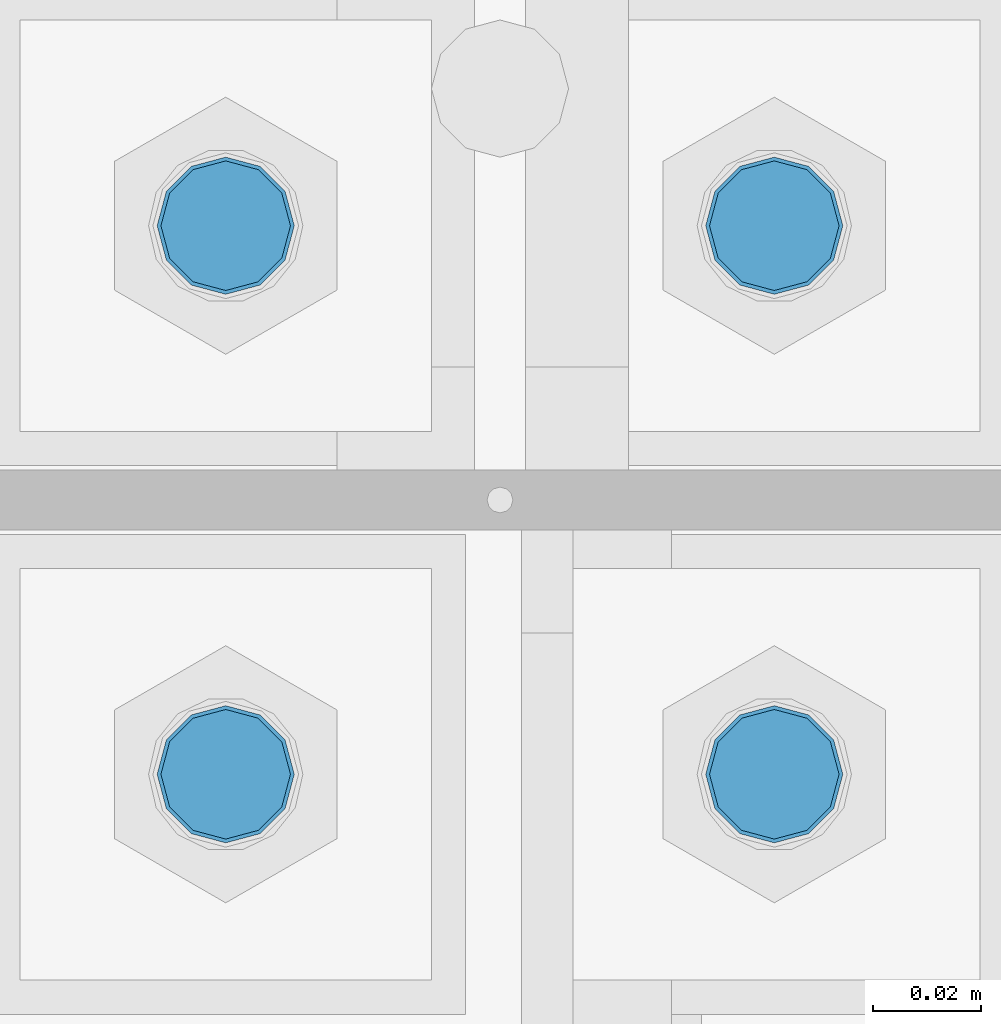
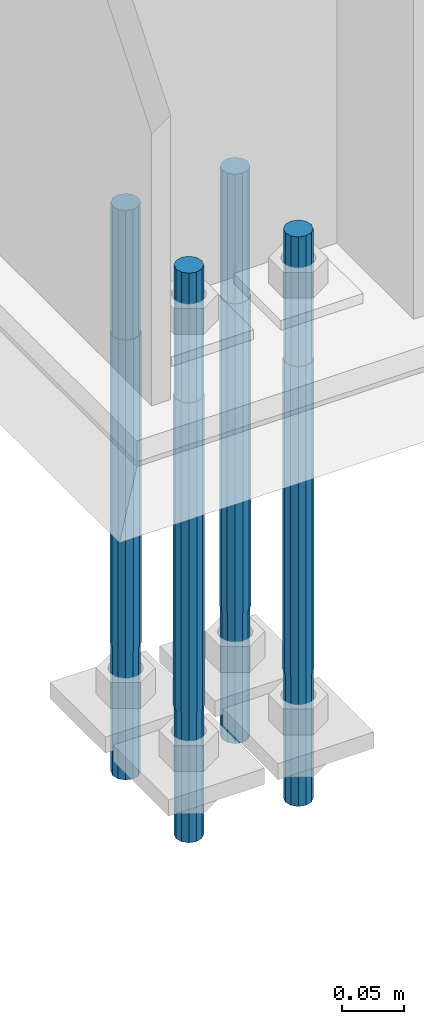
# One storey, part 1573 of 3843: 4 columns, 1 element without a shape of its own.
"""IFC2X3 building model written with IfcOpenShell, lengths in millimetres."""

from ifc_helpers import new_model, si_unit, frame, origin_with_axes, place, context, subcontext, project, spatial, faceted_brep, material, type_object, element, aggregate, save


model = new_model("IFC2X3")

# Units and contexts
model_context = context("Model", 3, precision=1e-05, world=origin_with_axes())
body_context = subcontext(model_context, "Body", "Model", "MODEL_VIEW")
ifc_project = project(units=[si_unit("LENGTHUNIT", "METRE", prefix="MILLI"), si_unit("AREAUNIT", "SQUARE_METRE"), si_unit("VOLUMEUNIT", "CUBIC_METRE"), si_unit("MASSUNIT", "GRAM", prefix="KILO"), si_unit("TIMEUNIT", "SECOND"), si_unit("PLANEANGLEUNIT", "RADIAN"), si_unit("SOLIDANGLEUNIT", "STERADIAN"), si_unit("THERMODYNAMICTEMPERATUREUNIT", "DEGREE_CELSIUS"), si_unit("LUMINOUSINTENSITYUNIT", "LUMEN")], contexts=[model_context])

# Site, building, storey
site_placement = place(None, origin_with_axes())
site = spatial("IfcSite", under=ifc_project, at=site_placement, CompositionType="ELEMENT")
building_placement = place(site_placement, origin_with_axes())
building = spatial("IfcBuilding", under=site, at=building_placement, Name="Undefined", CompositionType="ELEMENT")
storey_placement = place(building_placement, origin_with_axes())
storey = spatial("IfcBuildingStorey", under=building, at=storey_placement, Name="Undefined", CompositionType="ELEMENT", Elevation=0.0)

# Assembly, columns
assembly_placement = place(storey_placement, origin_with_axes())
assembly = element("IfcElementAssembly", 1, at=assembly_placement, inside=storey, Name="TEMPLATE", AssemblyPlace="NOTDEFINED", PredefinedType="RIGID_FRAME")
ifc_material = material(Name="Undefined/F1554-GR.55")
column_type = type_object("IfcColumnType", PredefinedType="NOTDEFINED")
column_1_placement = place(assembly_placement, frame((36626.8, 89065.1, 30022.8), z_axis=(1.0, 0.0, 0.0), x_axis=(0.0, 0.0, -1.0)))
column_1 = element("IfcColumn", 2, at=column_1_placement, type_object=column_type, material=ifc_material, Name="ANCHOR_ROD", context=body_context, shape_type="Brep", body=[
    faceted_brep([(-127.0, -10.3923048454162, 6.0), (-127.0, -6.0, 10.3923048454126), (-127.0, 0.0, 12.0), (-127.0, 6.0, 10.3923048454126), (-127.0, 10.3923048454162, 6.0), (-127.0, 12.0, 0.0), (-127.0, 10.3923048454162, -6.0), (-127.0, 6.0, -10.3923048454126), (-127.0, 0.0, -12.0), (-127.0, -6.0, -10.3923048454126), (-127.0, -10.3923048454162, -6.0), (-127.0, -12.0, 0.0), (0.0, 12.0, 0.0), (0.0, 10.3923048454162, -6.0), (0.0, 6.0, -10.3923048454126), (0.0, 0.0, -12.0), (0.0, -6.0, -10.3923048454126), (0.0, -10.3923048454162, -6.0), (0.0, -12.0, 0.0), (0.0, -10.3923048454162, 6.0), (0.0, -6.0, 10.3923048454126), (0.0, 0.0, 12.0), (0.0, 6.0, 10.3923048454126), (0.0, 10.3923048454162, 6.0), (0.0, -10.9985226280696, 6.34999999999854), (0.0, -6.35000000000582, 10.9985226280623), (0.0, 0.0, 12.6999999999971), (0.0, 6.35000000000582, 10.9985226280623), (0.0, 10.9985226280696, 6.34999999999854), (0.0, 12.6999999999971, 0.0), (0.0, 10.9985226280696, -6.34999999999854), (0.0, 6.35000000000582, -10.9985226280623), (0.0, 0.0, -12.6999999999971), (0.0, -6.35000000000582, -10.9985226280623), (0.0, -10.9985226280696, -6.34999999999854), (0.0, -12.6999999999971, 0.0), (304.799999999999, -12.6999999999971, 0.0), (304.799999999999, -10.9985226280623, 6.35000000000036), (304.799999999999, -6.34999999999854, 10.9985226280623), (304.799999999999, 0.0, 12.7000000000007), (304.799999999999, 6.34999999999854, 10.9985226280623), (304.799999999999, 10.9985226280623, 6.35000000000036), (304.799999999999, 12.6999999999971, 0.0), (304.799999999999, 10.9985226280623, -6.35000000000036), (304.799999999999, 6.34999999999854, -10.9985226280623), (304.799999999999, 0.0, -12.7000000000007), (304.799999999999, -6.34999999999854, -10.9985226280623), (304.799999999999, -10.9985226280623, -6.35000000000036), (304.799999999999, -6.0, 10.3923048454126), (304.799999999999, 0.0, 12.0), (304.799999999999, 6.0, 10.3923048454126), (304.799999999999, 10.3923048454162, 6.0), (304.799999999999, 12.0, 0.0), (304.799999999999, 10.3923048454162, -6.0), (304.799999999999, 6.0, -10.3923048454126), (304.799999999999, 0.0, -12.0), (304.799999999999, -6.0, -10.3923048454126), (304.799999999999, -10.3923048454162, -6.0), (304.799999999999, -12.0, 0.0), (304.799999999999, -10.3923048454162, 6.0), (431.799999999999, -6.0, -10.3923048454126), (431.799999999999, 0.0, -12.0), (431.799999999999, 6.0, -10.3923048454126), (431.799999999999, 10.3923048454162, -6.0), (431.799999999999, 12.0, 0.0), (431.799999999999, 10.3923048454162, 6.0), (431.799999999999, 6.0, 10.3923048454126), (431.799999999999, 0.0, 12.0), (431.799999999999, -6.0, 10.3923048454126), (431.799999999999, -10.3923048454162, 6.0), (431.799999999999, -12.0, 0.0), (431.799999999999, -10.3923048454162, -6.0)], [[[0, 1, 2, 3, 4, 5, 6, 7, 8, 9, 10, 11]], [[6, 5, 12, 13]], [[7, 6, 13, 14]], [[8, 7, 14, 15]], [[9, 8, 15, 16]], [[10, 9, 16, 17]], [[11, 10, 17, 18]], [[0, 11, 18, 19]], [[1, 0, 19, 20]], [[2, 1, 20, 21]], [[3, 2, 21, 22]], [[4, 3, 22, 23]], [[5, 4, 23, 12]], [[24, 25, 26, 27, 28, 29, 30, 31, 32, 33, 34, 35], [22, 21, 20, 19, 18, 17, 16, 15, 14, 13, 12, 23]], [[24, 35, 36, 37]], [[25, 24, 37, 38]], [[26, 25, 38, 39]], [[27, 26, 39, 40]], [[28, 27, 40, 41]], [[29, 28, 41, 42]], [[30, 29, 42, 43]], [[31, 30, 43, 44]], [[32, 31, 44, 45]], [[33, 32, 45, 46]], [[34, 33, 46, 47]], [[35, 34, 47, 36]], [[46, 45, 44, 43, 42, 41, 40, 39, 38, 37, 36, 47], [48, 49, 50, 51, 52, 53, 54, 55, 56, 57, 58, 59]], [[60, 61, 62, 63, 64, 65, 66, 67, 68, 69, 70, 71]], [[68, 67, 49, 48]], [[69, 68, 48, 59]], [[70, 69, 59, 58]], [[71, 70, 58, 57]], [[60, 71, 57, 56]], [[61, 60, 56, 55]], [[62, 61, 55, 54]], [[63, 62, 54, 53]], [[64, 63, 53, 52]], [[65, 64, 52, 51]], [[66, 65, 51, 50]], [[67, 66, 50, 49]]]),
])
column_2_placement = place(assembly_placement, frame((36626.8, 89166.7, 30022.8), z_axis=(-1.0, 0.0, 0.0), x_axis=(0.0, 0.0, -1.0)))
column_2 = element("IfcColumn", 3, at=column_2_placement, type_object=column_type, material=ifc_material, Name="ANCHOR_ROD", context=body_context, shape_type="Brep", body=[
    faceted_brep([(-127.0, -10.3923048454162, 6.0), (-127.0, -6.0, 10.3923048454126), (-127.0, 0.0, 12.0), (-127.0, 6.0, 10.3923048454126), (-127.0, 10.3923048454162, 6.0), (-127.0, 12.0, 0.0), (-127.0, 10.3923048454162, -6.0), (-127.0, 6.0, -10.3923048454126), (-127.0, 0.0, -12.0), (-127.0, -6.0, -10.3923048454126), (-127.0, -10.3923048454162, -6.0), (-127.0, -12.0, 0.0), (0.0, 12.0, 0.0), (0.0, 10.3923048454162, -6.0), (0.0, 6.0, -10.3923048454126), (0.0, 0.0, -12.0), (0.0, -6.0, -10.3923048454126), (0.0, -10.3923048454162, -6.0), (0.0, -12.0, 0.0), (0.0, -10.3923048454162, 6.0), (0.0, -6.0, 10.3923048454126), (0.0, 0.0, 12.0), (0.0, 6.0, 10.3923048454126), (0.0, 10.3923048454162, 6.0), (0.0, -10.9985226280696, 6.34999999999854), (0.0, -6.35000000000582, 10.9985226280623), (0.0, 0.0, 12.6999999999971), (0.0, 6.35000000000582, 10.9985226280623), (0.0, 10.9985226280696, 6.34999999999854), (0.0, 12.6999999999971, 0.0), (0.0, 10.9985226280696, -6.34999999999854), (0.0, 6.35000000000582, -10.9985226280623), (0.0, 0.0, -12.6999999999971), (0.0, -6.35000000000582, -10.9985226280623), (0.0, -10.9985226280696, -6.34999999999854), (0.0, -12.6999999999971, 0.0), (304.799999999999, -12.6999999999971, 0.0), (304.799999999999, -10.9985226280623, 6.35000000000036), (304.799999999999, -6.34999999999854, 10.9985226280623), (304.799999999999, 0.0, 12.7000000000007), (304.799999999999, 6.34999999999854, 10.9985226280623), (304.799999999999, 10.9985226280623, 6.35000000000036), (304.799999999999, 12.6999999999971, 0.0), (304.799999999999, 10.9985226280623, -6.35000000000036), (304.799999999999, 6.34999999999854, -10.9985226280623), (304.799999999999, 0.0, -12.7000000000007), (304.799999999999, -6.34999999999854, -10.9985226280623), (304.799999999999, -10.9985226280623, -6.35000000000036), (304.799999999999, -6.0, 10.3923048454126), (304.799999999999, 0.0, 12.0), (304.799999999999, 6.0, 10.3923048454126), (304.799999999999, 10.3923048454162, 6.0), (304.799999999999, 12.0, 0.0), (304.799999999999, 10.3923048454162, -6.0), (304.799999999999, 6.0, -10.3923048454126), (304.799999999999, 0.0, -12.0), (304.799999999999, -6.0, -10.3923048454126), (304.799999999999, -10.3923048454162, -6.0), (304.799999999999, -12.0, 0.0), (304.799999999999, -10.3923048454162, 6.0), (431.799999999999, -6.0, -10.3923048454126), (431.799999999999, 0.0, -12.0), (431.799999999999, 6.0, -10.3923048454126), (431.799999999999, 10.3923048454162, -6.0), (431.799999999999, 12.0, 0.0), (431.799999999999, 10.3923048454162, 6.0), (431.799999999999, 6.0, 10.3923048454126), (431.799999999999, 0.0, 12.0), (431.799999999999, -6.0, 10.3923048454126), (431.799999999999, -10.3923048454162, 6.0), (431.799999999999, -12.0, 0.0), (431.799999999999, -10.3923048454162, -6.0)], [[[0, 1, 2, 3, 4, 5, 6, 7, 8, 9, 10, 11]], [[6, 5, 12, 13]], [[7, 6, 13, 14]], [[8, 7, 14, 15]], [[9, 8, 15, 16]], [[10, 9, 16, 17]], [[11, 10, 17, 18]], [[0, 11, 18, 19]], [[1, 0, 19, 20]], [[2, 1, 20, 21]], [[3, 2, 21, 22]], [[4, 3, 22, 23]], [[5, 4, 23, 12]], [[24, 25, 26, 27, 28, 29, 30, 31, 32, 33, 34, 35], [22, 21, 20, 19, 18, 17, 16, 15, 14, 13, 12, 23]], [[24, 35, 36, 37]], [[25, 24, 37, 38]], [[26, 25, 38, 39]], [[27, 26, 39, 40]], [[28, 27, 40, 41]], [[29, 28, 41, 42]], [[30, 29, 42, 43]], [[31, 30, 43, 44]], [[32, 31, 44, 45]], [[33, 32, 45, 46]], [[34, 33, 46, 47]], [[35, 34, 47, 36]], [[46, 45, 44, 43, 42, 41, 40, 39, 38, 37, 36, 47], [48, 49, 50, 51, 52, 53, 54, 55, 56, 57, 58, 59]], [[60, 61, 62, 63, 64, 65, 66, 67, 68, 69, 70, 71]], [[68, 67, 49, 48]], [[69, 68, 48, 59]], [[70, 69, 59, 58]], [[71, 70, 58, 57]], [[60, 71, 57, 56]], [[61, 60, 56, 55]], [[62, 61, 55, 54]], [[63, 62, 54, 53]], [[64, 63, 53, 52]], [[65, 64, 52, 51]], [[66, 65, 51, 50]], [[67, 66, 50, 49]]]),
])
column_3_placement = place(assembly_placement, frame((36525.2, 89065.1, 30022.8), z_axis=(1.0, 0.0, 0.0), x_axis=(0.0, 0.0, -1.0)))
column_3 = element("IfcColumn", 4, at=column_3_placement, type_object=column_type, material=ifc_material, Name="ANCHOR_ROD", context=body_context, shape_type="Brep", body=[
    faceted_brep([(-127.0, -10.3923048454162, 6.0), (-127.0, -6.0, 10.3923048454126), (-127.0, 0.0, 12.0), (-127.0, 6.0, 10.3923048454126), (-127.0, 10.3923048454162, 6.0), (-127.0, 12.0, 0.0), (-127.0, 10.3923048454162, -6.0), (-127.0, 6.0, -10.3923048454126), (-127.0, 0.0, -12.0), (-127.0, -6.0, -10.3923048454126), (-127.0, -10.3923048454162, -6.0), (-127.0, -12.0, 0.0), (0.0, 12.0, 0.0), (0.0, 10.3923048454162, -6.0), (0.0, 6.0, -10.3923048454126), (0.0, 0.0, -12.0), (0.0, -6.0, -10.3923048454126), (0.0, -10.3923048454162, -6.0), (0.0, -12.0, 0.0), (0.0, -10.3923048454162, 6.0), (0.0, -6.0, 10.3923048454126), (0.0, 0.0, 12.0), (0.0, 6.0, 10.3923048454126), (0.0, 10.3923048454162, 6.0), (0.0, -10.9985226280696, 6.34999999999854), (0.0, -6.35000000000582, 10.9985226280623), (0.0, 0.0, 12.6999999999971), (0.0, 6.35000000000582, 10.9985226280623), (0.0, 10.9985226280696, 6.34999999999854), (0.0, 12.6999999999971, 0.0), (0.0, 10.9985226280696, -6.34999999999854), (0.0, 6.35000000000582, -10.9985226280623), (0.0, 0.0, -12.6999999999971), (0.0, -6.35000000000582, -10.9985226280623), (0.0, -10.9985226280696, -6.34999999999854), (0.0, -12.6999999999971, 0.0), (304.799999999999, -12.6999999999971, 0.0), (304.799999999999, -10.9985226280623, 6.35000000000036), (304.799999999999, -6.34999999999854, 10.9985226280623), (304.799999999999, 0.0, 12.7000000000007), (304.799999999999, 6.34999999999854, 10.9985226280623), (304.799999999999, 10.9985226280623, 6.35000000000036), (304.799999999999, 12.6999999999971, 0.0), (304.799999999999, 10.9985226280623, -6.35000000000036), (304.799999999999, 6.34999999999854, -10.9985226280623), (304.799999999999, 0.0, -12.7000000000007), (304.799999999999, -6.34999999999854, -10.9985226280623), (304.799999999999, -10.9985226280623, -6.35000000000036), (304.799999999999, -6.0, 10.3923048454126), (304.799999999999, 0.0, 12.0), (304.799999999999, 6.0, 10.3923048454126), (304.799999999999, 10.3923048454162, 6.0), (304.799999999999, 12.0, 0.0), (304.799999999999, 10.3923048454162, -6.0), (304.799999999999, 6.0, -10.3923048454126), (304.799999999999, 0.0, -12.0), (304.799999999999, -6.0, -10.3923048454126), (304.799999999999, -10.3923048454162, -6.0), (304.799999999999, -12.0, 0.0), (304.799999999999, -10.3923048454162, 6.0), (431.799999999999, -6.0, -10.3923048454126), (431.799999999999, 0.0, -12.0), (431.799999999999, 6.0, -10.3923048454126), (431.799999999999, 10.3923048454162, -6.0), (431.799999999999, 12.0, 0.0), (431.799999999999, 10.3923048454162, 6.0), (431.799999999999, 6.0, 10.3923048454126), (431.799999999999, 0.0, 12.0), (431.799999999999, -6.0, 10.3923048454126), (431.799999999999, -10.3923048454162, 6.0), (431.799999999999, -12.0, 0.0), (431.799999999999, -10.3923048454162, -6.0)], [[[0, 1, 2, 3, 4, 5, 6, 7, 8, 9, 10, 11]], [[6, 5, 12, 13]], [[7, 6, 13, 14]], [[8, 7, 14, 15]], [[9, 8, 15, 16]], [[10, 9, 16, 17]], [[11, 10, 17, 18]], [[0, 11, 18, 19]], [[1, 0, 19, 20]], [[2, 1, 20, 21]], [[3, 2, 21, 22]], [[4, 3, 22, 23]], [[5, 4, 23, 12]], [[24, 25, 26, 27, 28, 29, 30, 31, 32, 33, 34, 35], [22, 21, 20, 19, 18, 17, 16, 15, 14, 13, 12, 23]], [[24, 35, 36, 37]], [[25, 24, 37, 38]], [[26, 25, 38, 39]], [[27, 26, 39, 40]], [[28, 27, 40, 41]], [[29, 28, 41, 42]], [[30, 29, 42, 43]], [[31, 30, 43, 44]], [[32, 31, 44, 45]], [[33, 32, 45, 46]], [[34, 33, 46, 47]], [[35, 34, 47, 36]], [[46, 45, 44, 43, 42, 41, 40, 39, 38, 37, 36, 47], [48, 49, 50, 51, 52, 53, 54, 55, 56, 57, 58, 59]], [[60, 61, 62, 63, 64, 65, 66, 67, 68, 69, 70, 71]], [[68, 67, 49, 48]], [[69, 68, 48, 59]], [[70, 69, 59, 58]], [[71, 70, 58, 57]], [[60, 71, 57, 56]], [[61, 60, 56, 55]], [[62, 61, 55, 54]], [[63, 62, 54, 53]], [[64, 63, 53, 52]], [[65, 64, 52, 51]], [[66, 65, 51, 50]], [[67, 66, 50, 49]]]),
])
column_4_placement = place(assembly_placement, frame((36525.2, 89166.7, 30022.8), z_axis=(-1.0, 0.0, 0.0), x_axis=(0.0, 0.0, -1.0)))
column_4 = element("IfcColumn", 5, at=column_4_placement, type_object=column_type, material=ifc_material, Name="ANCHOR_ROD", context=body_context, shape_type="Brep", body=[
    faceted_brep([(-127.0, -10.3923048454162, 6.0), (-127.0, -6.0, 10.3923048454126), (-127.0, 0.0, 12.0), (-127.0, 6.0, 10.3923048454126), (-127.0, 10.3923048454162, 6.0), (-127.0, 12.0, 0.0), (-127.0, 10.3923048454162, -6.0), (-127.0, 6.0, -10.3923048454126), (-127.0, 0.0, -12.0), (-127.0, -6.0, -10.3923048454126), (-127.0, -10.3923048454162, -6.0), (-127.0, -12.0, 0.0), (0.0, 12.0, 0.0), (0.0, 10.3923048454162, -6.0), (0.0, 6.0, -10.3923048454126), (0.0, 0.0, -12.0), (0.0, -6.0, -10.3923048454126), (0.0, -10.3923048454162, -6.0), (0.0, -12.0, 0.0), (0.0, -10.3923048454162, 6.0), (0.0, -6.0, 10.3923048454126), (0.0, 0.0, 12.0), (0.0, 6.0, 10.3923048454126), (0.0, 10.3923048454162, 6.0), (0.0, -10.9985226280696, 6.34999999999854), (0.0, -6.35000000000582, 10.9985226280623), (0.0, 0.0, 12.6999999999971), (0.0, 6.35000000000582, 10.9985226280623), (0.0, 10.9985226280696, 6.34999999999854), (0.0, 12.6999999999971, 0.0), (0.0, 10.9985226280696, -6.34999999999854), (0.0, 6.35000000000582, -10.9985226280623), (0.0, 0.0, -12.6999999999971), (0.0, -6.35000000000582, -10.9985226280623), (0.0, -10.9985226280696, -6.34999999999854), (0.0, -12.6999999999971, 0.0), (304.799999999999, -12.6999999999971, 0.0), (304.799999999999, -10.9985226280623, 6.35000000000036), (304.799999999999, -6.34999999999854, 10.9985226280623), (304.799999999999, 0.0, 12.7000000000007), (304.799999999999, 6.34999999999854, 10.9985226280623), (304.799999999999, 10.9985226280623, 6.35000000000036), (304.799999999999, 12.6999999999971, 0.0), (304.799999999999, 10.9985226280623, -6.35000000000036), (304.799999999999, 6.34999999999854, -10.9985226280623), (304.799999999999, 0.0, -12.7000000000007), (304.799999999999, -6.34999999999854, -10.9985226280623), (304.799999999999, -10.9985226280623, -6.35000000000036), (304.799999999999, -6.0, 10.3923048454126), (304.799999999999, 0.0, 12.0), (304.799999999999, 6.0, 10.3923048454126), (304.799999999999, 10.3923048454162, 6.0), (304.799999999999, 12.0, 0.0), (304.799999999999, 10.3923048454162, -6.0), (304.799999999999, 6.0, -10.3923048454126), (304.799999999999, 0.0, -12.0), (304.799999999999, -6.0, -10.3923048454126), (304.799999999999, -10.3923048454162, -6.0), (304.799999999999, -12.0, 0.0), (304.799999999999, -10.3923048454162, 6.0), (431.799999999999, -6.0, -10.3923048454126), (431.799999999999, 0.0, -12.0), (431.799999999999, 6.0, -10.3923048454126), (431.799999999999, 10.3923048454162, -6.0), (431.799999999999, 12.0, 0.0), (431.799999999999, 10.3923048454162, 6.0), (431.799999999999, 6.0, 10.3923048454126), (431.799999999999, 0.0, 12.0), (431.799999999999, -6.0, 10.3923048454126), (431.799999999999, -10.3923048454162, 6.0), (431.799999999999, -12.0, 0.0), (431.799999999999, -10.3923048454162, -6.0)], [[[0, 1, 2, 3, 4, 5, 6, 7, 8, 9, 10, 11]], [[6, 5, 12, 13]], [[7, 6, 13, 14]], [[8, 7, 14, 15]], [[9, 8, 15, 16]], [[10, 9, 16, 17]], [[11, 10, 17, 18]], [[0, 11, 18, 19]], [[1, 0, 19, 20]], [[2, 1, 20, 21]], [[3, 2, 21, 22]], [[4, 3, 22, 23]], [[5, 4, 23, 12]], [[24, 25, 26, 27, 28, 29, 30, 31, 32, 33, 34, 35], [22, 21, 20, 19, 18, 17, 16, 15, 14, 13, 12, 23]], [[24, 35, 36, 37]], [[25, 24, 37, 38]], [[26, 25, 38, 39]], [[27, 26, 39, 40]], [[28, 27, 40, 41]], [[29, 28, 41, 42]], [[30, 29, 42, 43]], [[31, 30, 43, 44]], [[32, 31, 44, 45]], [[33, 32, 45, 46]], [[34, 33, 46, 47]], [[35, 34, 47, 36]], [[46, 45, 44, 43, 42, 41, 40, 39, 38, 37, 36, 47], [48, 49, 50, 51, 52, 53, 54, 55, 56, 57, 58, 59]], [[60, 61, 62, 63, 64, 65, 66, 67, 68, 69, 70, 71]], [[68, 67, 49, 48]], [[69, 68, 48, 59]], [[70, 69, 59, 58]], [[71, 70, 58, 57]], [[60, 71, 57, 56]], [[61, 60, 56, 55]], [[62, 61, 55, 54]], [[63, 62, 54, 53]], [[64, 63, 53, 52]], [[65, 64, 52, 51]], [[66, 65, 51, 50]], [[67, 66, 50, 49]]]),
])
aggregate(assembly, [column_1, column_2, column_3, column_4])

save(model, "model.ifc")
